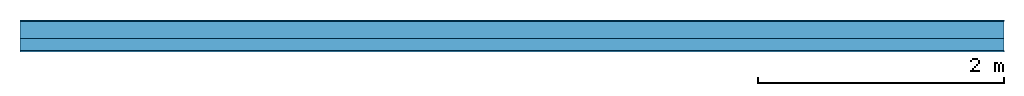
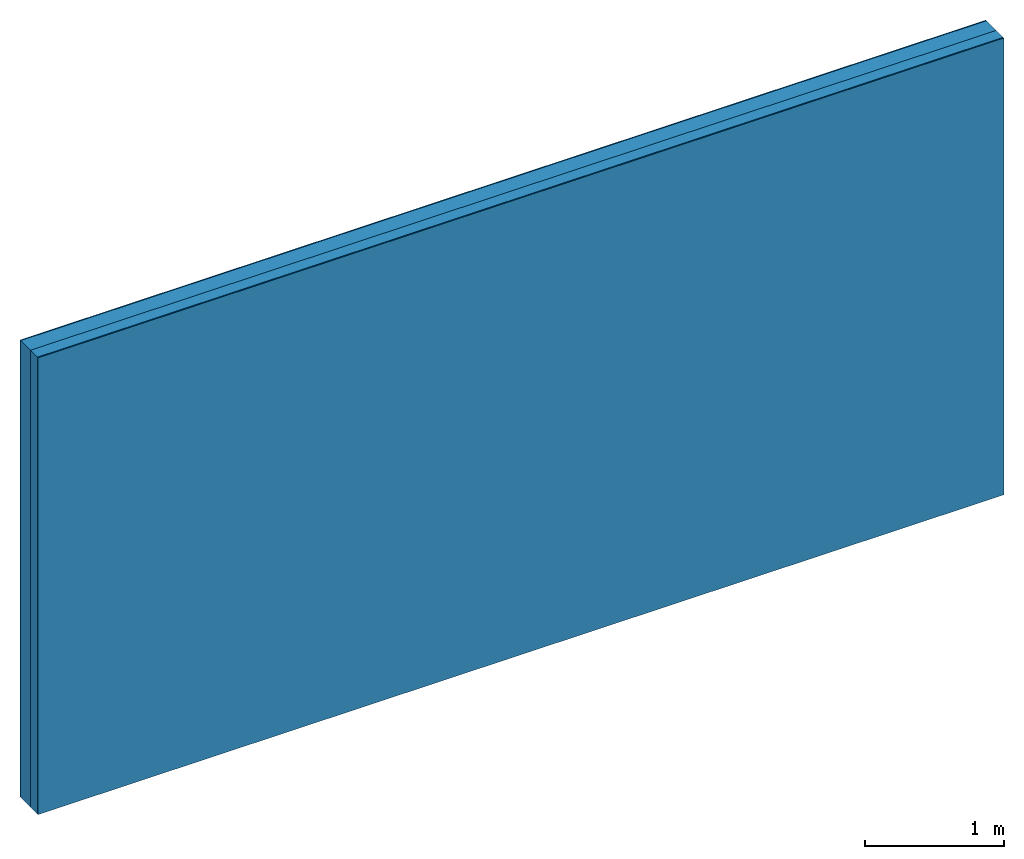
# One storey: 3 plates, 1 member, 1 element without a shape of its own.
"""IFC4 building model written with IfcOpenShell, lengths in metres."""

from ifc_helpers import new_model, si_unit, derived_unit, direction, frame, frame_2d, origin, origin_with_axes, place, context, project, spatial, rectangle, extrude, material, layer, layer_set, type_object, element, aggregate, save


model = new_model("IFC4")

# Units and contexts
plan_context = context("Plan", 3, precision=1e-05, world=origin(), true_north=direction((0.0, 1.0)))
model_context = context("Model", 3, precision=1e-05, world=origin(), true_north=direction((0.0, 1.0)))
ifc_project = project(units=[si_unit("LENGTHUNIT", "METRE"), derived_unit("SOUNDPRESSUREUNIT", [(si_unit("PRESSUREUNIT", "PASCAL", prefix="MICRO"), 0)]), si_unit("ENERGYUNIT", "JOULE", prefix="MEGA"), si_unit("MASSUNIT", "GRAM", prefix="KILO"), derived_unit("THERMALTRANSMITTANCEUNIT", [(si_unit("POWERUNIT", "WATT"), 1), (si_unit("AREAUNIT", "SQUARE_METRE"), -1), (si_unit("THERMODYNAMICTEMPERATUREUNIT", "KELVIN"), -1)]), derived_unit("AREADENSITYUNIT", [(si_unit("MASSUNIT", "GRAM", prefix="KILO"), 1), (si_unit("AREAUNIT", "SQUARE_METRE"), -1)]), derived_unit("USERDEFINED", [(si_unit("ENERGYUNIT", "JOULE", prefix="MEGA"), 1), (si_unit("AREAUNIT", "SQUARE_METRE"), -1)])], contexts=[plan_context, model_context])

# Site, building, storey
site = spatial("IfcSite", under=ifc_project)
building_placement = place(None, origin())
building = spatial("IfcBuilding", under=site, at=building_placement)
storey_placement = place(building_placement, origin())
storey = spatial("IfcBuildingStorey", under=building, at=storey_placement)

# Wall, member, plates
ifc_material_1 = material(Name="Mineral Knauf SM 700")
ifc_layer_1 = layer(ifc_material_1, 0.01, Name="Surface 1")
ifc_material_2 = material(Category="10.008")
ifc_layer_2 = layer(ifc_material_2, 0.14, Name="outside 1st layer")
ifc_material_3 = material(Name="of the art")
ifc_layer_3 = layer(ifc_material_3, 0.0, Name="Bond")
ifc_layer_4 = layer(None, 0.1, Name="Support")
ifc_material_4 = material(Name="Rigid, of the art")
ifc_layer_5 = layer(ifc_material_4, 0.0, Name="Bond")
ifc_layer_6 = layer(ifc_material_1, 0.01, Name="Surface")
ifc_layer_set = layer_set([ifc_layer_1, ifc_layer_2, ifc_layer_3, ifc_layer_4, ifc_layer_5, ifc_layer_6])
wall_type = type_object("IfcWallType", Name="D1200", PredefinedType="NOTDEFINED", material=ifc_layer_set)
wall_placement = place(None, frame((0.0, 0.0, 0.0), z_axis=(0.0, -1.0, 0.0), x_axis=(1.0, 0.0, 0.0)))
wall = element("IfcWall", 1, at=wall_placement, inside=storey, type_object=wall_type, material=ifc_layer_set, Name="Wall #1")
ifc_material_5 = material(Name="OSB")
member_placement = place(wall_placement, origin())
member = element("IfcMember", 2, at=member_placement, material=ifc_material_5, Name="Support", context=plan_context, shape_type="SweptSolid", body=[
    extrude(rectangle(XDim=1.0, YDim=0.1, at=frame_2d((0.5, 0.05), x_axis=(1.0, 0.0))), frame((0.0, 4.0, 0.15), z_axis=(0.0, -1.0, 0.0), x_axis=(1.0, 0.0, 0.0)), (0.0, 0.0, 1.0), 4.0),
    extrude(rectangle(XDim=1.0, YDim=0.1, at=frame_2d((0.5, 0.05), x_axis=(1.0, 0.0))), frame((1.0, 4.0, 0.15), z_axis=(0.0, -1.0, 0.0), x_axis=(1.0, 0.0, 0.0)), (0.0, 0.0, 1.0), 4.0),
    extrude(rectangle(XDim=1.0, YDim=0.1, at=frame_2d((0.5, 0.05), x_axis=(1.0, 0.0))), frame((2.0, 4.0, 0.15), z_axis=(0.0, -1.0, 0.0), x_axis=(1.0, 0.0, 0.0)), (0.0, 0.0, 1.0), 4.0),
    extrude(rectangle(XDim=1.0, YDim=0.1, at=frame_2d((0.5, 0.05), x_axis=(1.0, 0.0))), frame((3.0, 4.0, 0.15), z_axis=(0.0, -1.0, 0.0), x_axis=(1.0, 0.0, 0.0)), (0.0, 0.0, 1.0), 4.0),
    extrude(rectangle(XDim=1.0, YDim=0.1, at=frame_2d((0.5, 0.05), x_axis=(1.0, 0.0))), frame((4.0, 4.0, 0.15), z_axis=(0.0, -1.0, 0.0), x_axis=(1.0, 0.0, 0.0)), (0.0, 0.0, 1.0), 4.0),
    extrude(rectangle(XDim=1.0, YDim=0.1, at=frame_2d((0.5, 0.05), x_axis=(1.0, 0.0))), frame((5.0, 4.0, 0.15), z_axis=(0.0, -1.0, 0.0), x_axis=(1.0, 0.0, 0.0)), (0.0, 0.0, 1.0), 4.0),
    extrude(rectangle(XDim=1.0, YDim=0.1, at=frame_2d((0.5, 0.05), x_axis=(1.0, 0.0))), frame((6.0, 4.0, 0.15), z_axis=(0.0, -1.0, 0.0), x_axis=(1.0, 0.0, 0.0)), (0.0, 0.0, 1.0), 4.0),
    extrude(rectangle(XDim=1.0, YDim=0.1, at=frame_2d((0.5, 0.05), x_axis=(1.0, 0.0))), frame((7.0, 4.0, 0.15), z_axis=(0.0, -1.0, 0.0), x_axis=(1.0, 0.0, 0.0)), (0.0, 0.0, 1.0), 4.0),
])
plate_1_placement = place(wall_placement, origin())
plate_1 = element("IfcPlate", 3, at=plate_1_placement, material=ifc_material_1, Name="Surface 1", context=plan_context, shape_type="SweptSolid", body=[
    extrude(rectangle(XDim=8.0, YDim=4.0, at=frame_2d((4.0, 2.0), x_axis=(1.0, 0.0))), origin_with_axes(), (0.0, 0.0, 1.0), 0.01),
])
plate_2_placement = place(wall_placement, origin())
plate_2 = element("IfcPlate", 4, at=plate_2_placement, material=ifc_material_2, Name="outside 1st layer", context=plan_context, shape_type="SweptSolid", body=[
    extrude(rectangle(XDim=8.0, YDim=4.0, at=frame_2d((4.0, 2.0), x_axis=(1.0, 0.0))), frame((0.0, 0.0, 0.01), z_axis=(0.0, 0.0, 1.0), x_axis=(1.0, 0.0, 0.0)), (0.0, 0.0, 1.0), 0.14),
])
plate_3_placement = place(wall_placement, origin())
plate_3 = element("IfcPlate", 5, at=plate_3_placement, material=ifc_material_1, Name="Surface", context=plan_context, shape_type="SweptSolid", body=[
    extrude(rectangle(XDim=8.0, YDim=4.0, at=frame_2d((4.0, 2.0), x_axis=(1.0, 0.0))), frame((0.0, 0.0, 0.25), z_axis=(0.0, 0.0, 1.0), x_axis=(1.0, 0.0, 0.0)), (0.0, 0.0, 1.0), 0.01),
])
aggregate(wall, [plate_1, plate_2, member, plate_3])

save(model, "model.ifc")
